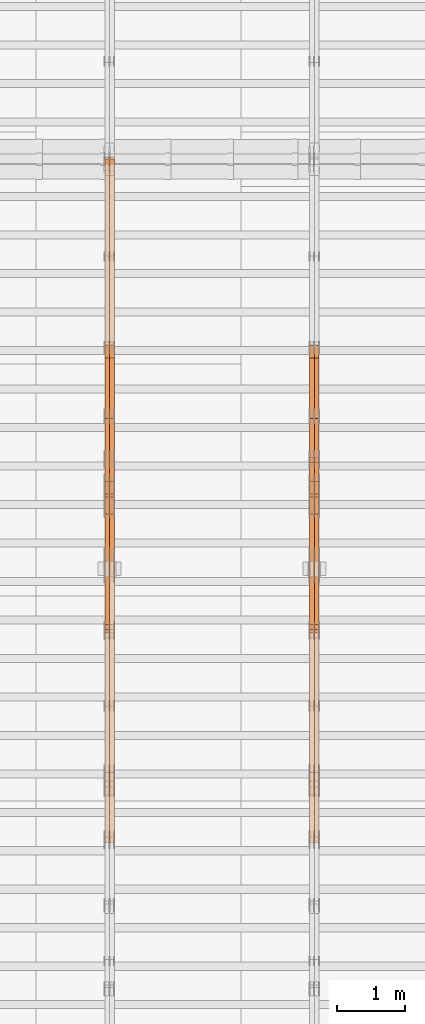
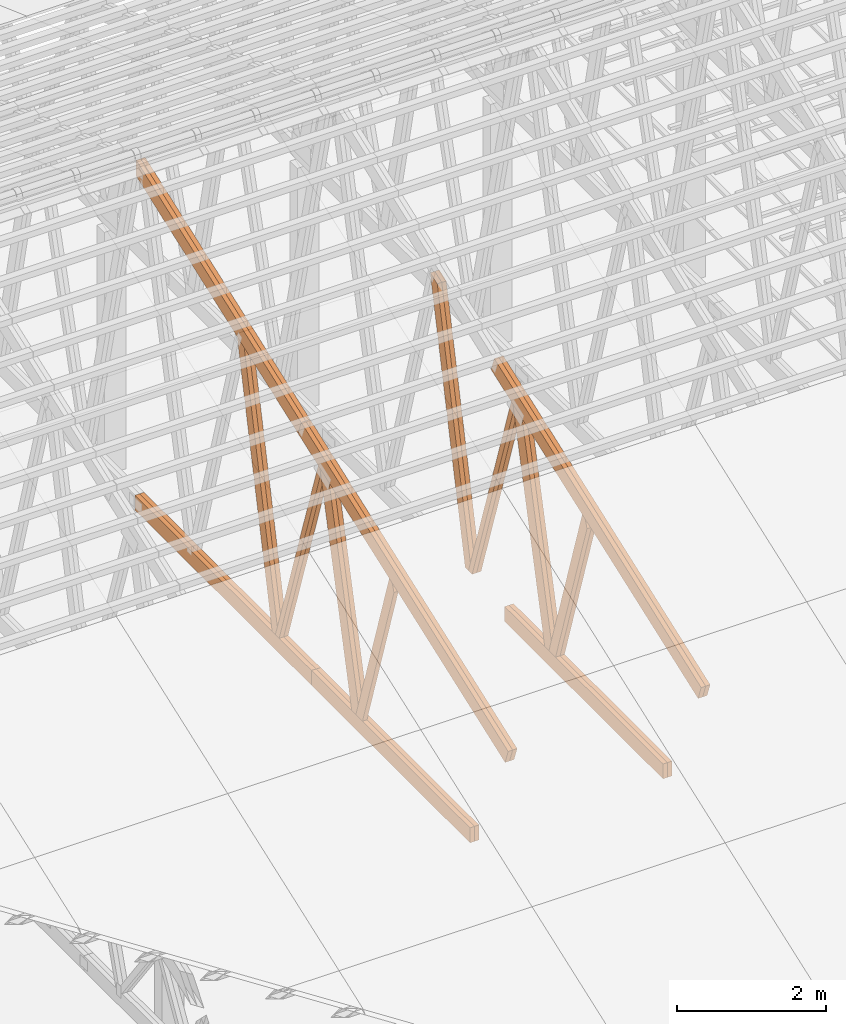
# One storey, part 49 of 189: 27 proxies.
"""IFC2X3 building model written with IfcOpenShell, lengths in millimetres."""

from ifc_helpers import new_model, entity, si_unit, converted_unit, derived_unit, direction, frame, origin, origin_2d_with_axis, place, context, subcontext, project, spatial, polyline, rectangle, outline, extrude, source, transform, mapped, material, type_object, type_shapes, element, save


model = new_model("IFC2X3")

# Units and contexts
model_context = context("Model", 3, precision=0.01, world=origin(), true_north=direction((6.12303176911189e-17, 1.0)))
body_context = subcontext(model_context, "Body", "Model", "MODEL_VIEW")
ifc_project = project(units=[si_unit("LENGTHUNIT", "METRE", prefix="MILLI"), si_unit("AREAUNIT", "SQUARE_METRE"), si_unit("VOLUMEUNIT", "CUBIC_METRE"), converted_unit("PLANEANGLEUNIT", "DEGREE", entity("IfcRatioMeasure", 0.0174532925199433), si_unit("PLANEANGLEUNIT", "RADIAN"), dimensions=[0, 0, 0, 0, 0, 0, 0]), si_unit("MASSUNIT", "GRAM", prefix="KILO"), derived_unit("MASSDENSITYUNIT", [(si_unit("MASSUNIT", "GRAM", prefix="KILO"), 1), (si_unit("LENGTHUNIT", "METRE"), -3)]), si_unit("TIMEUNIT", "SECOND"), si_unit("FREQUENCYUNIT", "HERTZ"), si_unit("THERMODYNAMICTEMPERATUREUNIT", "DEGREE_CELSIUS"), derived_unit("THERMALTRANSMITTANCEUNIT", [(si_unit("MASSUNIT", "GRAM", prefix="KILO"), 1), (si_unit("THERMODYNAMICTEMPERATUREUNIT", "KELVIN"), -1), (si_unit("TIMEUNIT", "SECOND"), -3)]), derived_unit("VOLUMETRICFLOWRATEUNIT", [(si_unit("LENGTHUNIT", "METRE"), 3), (si_unit("TIMEUNIT", "SECOND"), -1)]), si_unit("ELECTRICCURRENTUNIT", "AMPERE"), si_unit("ELECTRICVOLTAGEUNIT", "VOLT"), si_unit("POWERUNIT", "WATT"), si_unit("FORCEUNIT", "NEWTON"), si_unit("ILLUMINANCEUNIT", "LUX"), si_unit("LUMINOUSFLUXUNIT", "LUMEN"), si_unit("LUMINOUSINTENSITYUNIT", "CANDELA"), derived_unit("USERDEFINED", [(si_unit("MASSUNIT", "GRAM", prefix="KILO"), -1), (si_unit("LENGTHUNIT", "METRE"), -2), (si_unit("TIMEUNIT", "SECOND"), 3), (si_unit("LUMINOUSFLUXUNIT", "LUMEN"), 1)]), derived_unit("LINEARVELOCITYUNIT", [(si_unit("LENGTHUNIT", "METRE"), 1), (si_unit("TIMEUNIT", "SECOND"), -1)]), si_unit("PRESSUREUNIT", "PASCAL"), derived_unit("USERDEFINED", [(si_unit("LENGTHUNIT", "METRE"), -2), (si_unit("MASSUNIT", "GRAM", prefix="KILO"), 1), (si_unit("TIMEUNIT", "SECOND"), -2)])], contexts=[model_context])

# Site, building, storey
site_placement = place(None, origin())
site = spatial("IfcSite", under=ifc_project, at=site_placement, CompositionType="ELEMENT")
building_placement = place(site_placement, origin())
building = spatial("IfcBuilding", under=site, at=building_placement, CompositionType="ELEMENT")
storey_placement = place(building_placement, origin())
storey = spatial("IfcBuildingStorey", under=building, at=storey_placement, Name="Default", CompositionType="ELEMENT", Elevation=0.0)

# Proxies
ifc_material_1 = material(Name="IfcSurfaceStyle #194426")
building_element_proxy_type_1 = type_object("IfcBuildingElementProxyType", Name="T1-W3 194424", PredefinedType="NOTDEFINED", material=ifc_material_1)
shared_shape_1 = source(origin(), body_context, "Body", "SweptSolid", [
    extrude(outline(polyline([(-2625.55080717397, -84.9998286237256), (1749.48871563991, -84.9998286237256), (1768.20584427244, 0.000602085469291858), (1625.445846867, 85.0000405971208), (-2517.58959960538, 84.9990145648612), (-2625.55080717397, -84.9998286237256)])), frame((1768.20584427244, 85.0000405971208, 0.0), z_axis=(0.0, 0.0, 1.0), x_axis=(-1.0, 0.0, 0.0)), (0.0, 0.0, 1.0), 69.9999999999997),
])
type_shapes(building_element_proxy_type_1, [shared_shape_1])
proxy_1_placement = place(building_placement, frame((36300.0, 10918.6728403286, 263.278932236374), z_axis=(-1.0, 0.0, 0.0), x_axis=(0.0, 0.215047682154604, 0.976603550269982)))
element("IfcBuildingElementProxy", 1, at=proxy_1_placement, inside=storey, type_object=building_element_proxy_type_1, material=ifc_material_1, Name="T1-W3", context=body_context, shape_type="MappedRepresentation", body=[
    mapped(shared_shape_1, transform((0.0, 0.0, 0.0), scale=1.0)),
])
ifc_material_2 = material(Name="IfcSurfaceStyle #194360")
building_element_proxy_type_2 = type_object("IfcBuildingElementProxyType", Name="T1-W3 194358", PredefinedType="NOTDEFINED", material=ifc_material_2)
shared_shape_2 = source(origin(), body_context, "Body", "SweptSolid", [
    extrude(outline(polyline([(-2625.55080717397, -84.9998286237256), (1749.48871563991, -84.9998286237256), (1768.20584427244, 0.000602085469291858), (1625.445846867, 85.0000405971208), (-2517.58959960538, 84.9990145648612), (-2625.55080717397, -84.9998286237256)])), frame((1768.20584427244, 85.0000405971208, 0.0), z_axis=(0.0, 0.0, 1.0), x_axis=(-1.0, 0.0, 0.0)), (0.0, 0.0, 1.0), 69.9999999999997),
])
type_shapes(building_element_proxy_type_2, [shared_shape_2])
proxy_2_placement = place(building_placement, frame((36230.0, 10918.6728403286, 263.278932236374), z_axis=(-1.0, 0.0, 0.0), x_axis=(0.0, 0.215047682154604, 0.976603550269982)))
element("IfcBuildingElementProxy", 2, at=proxy_2_placement, inside=storey, type_object=building_element_proxy_type_2, material=ifc_material_2, Name="T1-W3", context=body_context, shape_type="MappedRepresentation", body=[
    mapped(shared_shape_2, transform((0.0, 0.0, 0.0), scale=1.0)),
])
ifc_material_3 = material(Name="IfcSurfaceStyle #194162")
building_element_proxy_type_3 = type_object("IfcBuildingElementProxyType", Name="T1-W7 194160", PredefinedType="NOTDEFINED", material=ifc_material_3)
shared_shape_3 = source(origin(), body_context, "Body", "SweptSolid", [
    extrude(outline(polyline([(-2158.15323194511, -47.5001976605119), (1398.58481981178, -47.5001976605119), (1473.93376219819, -0.000131511554346808), (1475.30069254941, 47.5002634162891), (-2189.66604261427, 47.5002634162891), (-2158.15323194511, -47.5001976605119)])), frame((1475.30069254941, 47.5002634162891, 0.0), z_axis=(0.0, 0.0, 1.0), x_axis=(-1.0, 0.0, 0.0)), (0.0, 0.0, 1.0), 69.9999999999998),
])
type_shapes(building_element_proxy_type_3, [shared_shape_3])
proxy_3_placement = place(building_placement, frame((36300.0, 9847.787109375, 3723.57788085937), z_axis=(-1.0, 0.0, 0.0), x_axis=(0.0, 0.314845237923105, -0.949143021971475)))
element("IfcBuildingElementProxy", 3, at=proxy_3_placement, inside=storey, type_object=building_element_proxy_type_3, material=ifc_material_3, Name="T1-W7", context=body_context, shape_type="MappedRepresentation", body=[
    mapped(shared_shape_3, transform((0.0, 0.0, 0.0), scale=1.0)),
])
ifc_material_4 = material(Name="IfcSurfaceStyle #194096")
building_element_proxy_type_4 = type_object("IfcBuildingElementProxyType", Name="T1-W7 194094", PredefinedType="NOTDEFINED", material=ifc_material_4)
shared_shape_4 = source(origin(), body_context, "Body", "SweptSolid", [
    extrude(outline(polyline([(-2158.15323194511, -47.5001976605119), (1398.58481981178, -47.5001976605119), (1473.93376219819, -0.000131511554346808), (1475.30069254941, 47.5002634162891), (-2189.66604261427, 47.5002634162891), (-2158.15323194511, -47.5001976605119)])), frame((1475.30069254941, 47.5002634162891, 0.0), z_axis=(0.0, 0.0, 1.0), x_axis=(-1.0, 0.0, 0.0)), (0.0, 0.0, 1.0), 69.9999999999998),
])
type_shapes(building_element_proxy_type_4, [shared_shape_4])
proxy_4_placement = place(building_placement, frame((36230.0, 9847.787109375, 3723.57788085937), z_axis=(-1.0, 0.0, 0.0), x_axis=(0.0, 0.314845237923105, -0.949143021971475)))
element("IfcBuildingElementProxy", 4, at=proxy_4_placement, inside=storey, type_object=building_element_proxy_type_4, material=ifc_material_4, Name="T1-W7", context=body_context, shape_type="MappedRepresentation", body=[
    mapped(shared_shape_4, transform((0.0, 0.0, 0.0), scale=1.0)),
])
ifc_material_5 = material(Name="IfcSurfaceStyle #193898")
building_element_proxy_type_5 = type_object("IfcBuildingElementProxyType", Name="T1-W1 193896", PredefinedType="NOTDEFINED", material=ifc_material_5)
shared_shape_5 = source(origin(), body_context, "Body", "SweptSolid", [
    extrude(outline(polyline([(-2144.69382208629, -109.99948311278), (1421.70798092021, -109.99948311278), (1448.88116133745, -0.000392715405943322), (1271.09900468242, 109.999679470483), (-1996.99432485378, 109.999679470483), (-2144.69382208629, -109.99948311278)])), frame((1448.88130194731, 110.000176487146, 0.0), z_axis=(0.0, 0.0, 1.0), x_axis=(-1.0, 0.0, 0.0)), (0.0, 0.0, 1.0), 69.9999999999998),
])
type_shapes(building_element_proxy_type_5, [shared_shape_5])
proxy_5_placement = place(building_placement, frame((36300.0, 8727.74270166583, 271.380182391418), z_axis=(-1.0, 0.0, 0.0), x_axis=(0.0, 0.239819839925978, 0.970817410421691)))
element("IfcBuildingElementProxy", 5, at=proxy_5_placement, inside=storey, type_object=building_element_proxy_type_5, material=ifc_material_5, Name="T1-W1", context=body_context, shape_type="MappedRepresentation", body=[
    mapped(shared_shape_5, transform((0.0, 0.0, 0.0), scale=1.0)),
])
ifc_material_6 = material(Name="IfcSurfaceStyle #193832")
building_element_proxy_type_6 = type_object("IfcBuildingElementProxyType", Name="T1-W1 193830", PredefinedType="NOTDEFINED", material=ifc_material_6)
shared_shape_6 = source(origin(), body_context, "Body", "SweptSolid", [
    extrude(outline(polyline([(-2144.69382208629, -109.99948311278), (1421.70798092021, -109.99948311278), (1448.88116133745, -0.000392715405943322), (1271.09900468242, 109.999679470483), (-1996.99432485378, 109.999679470483), (-2144.69382208629, -109.99948311278)])), frame((1448.88130194731, 110.000176487146, 0.0), z_axis=(0.0, 0.0, 1.0), x_axis=(-1.0, 0.0, 0.0)), (0.0, 0.0, 1.0), 69.9999999999998),
])
type_shapes(building_element_proxy_type_6, [shared_shape_6])
proxy_6_placement = place(building_placement, frame((36230.0, 8727.74270166583, 271.380182391418), z_axis=(-1.0, 0.0, 0.0), x_axis=(0.0, 0.239819839925978, 0.970817410421691)))
element("IfcBuildingElementProxy", 6, at=proxy_6_placement, inside=storey, type_object=building_element_proxy_type_6, material=ifc_material_6, Name="T1-W1", context=body_context, shape_type="MappedRepresentation", body=[
    mapped(shared_shape_6, transform((0.0, 0.0, 0.0), scale=1.0)),
])
ifc_material_7 = material(Name="IfcSurfaceStyle #193634")
building_element_proxy_type_7 = type_object("IfcBuildingElementProxyType", Name="T1-W4 193632", PredefinedType="NOTDEFINED", material=ifc_material_7)
shared_shape_7 = source(origin(), body_context, "Body", "SweptSolid", [
    extrude(outline(polyline([(-1688.09292256655, -85.0003489723785), (1071.44998120742, -85.0003489723785), (1178.19407811536, -0.00016040063201781), (1181.35435681367, 85.0004291726946), (-1742.9054935699, 85.0004291726946), (-1688.09292256655, -85.0003489723785)])), frame((1181.35446122976, 85.0007670757732, 0.0), z_axis=(0.0, 0.0, 1.0), x_axis=(-1.0, 0.0, 0.0)), (0.0, 0.0, 1.0), 69.9999999999998),
])
type_shapes(building_element_proxy_type_7, [shared_shape_7])
proxy_7_placement = place(building_placement, frame((36300.0, 7937.17021143291, 3028.170124945), z_axis=(-1.0, 0.0, 0.0), x_axis=(0.0, 0.306868406216492, -0.951751953644514)))
element("IfcBuildingElementProxy", 7, at=proxy_7_placement, inside=storey, type_object=building_element_proxy_type_7, material=ifc_material_7, Name="T1-W4", context=body_context, shape_type="MappedRepresentation", body=[
    mapped(shared_shape_7, transform((0.0, 0.0, 0.0), scale=1.0)),
])
ifc_material_8 = material(Name="IfcSurfaceStyle #193568")
building_element_proxy_type_8 = type_object("IfcBuildingElementProxyType", Name="T1-W4 193566", PredefinedType="NOTDEFINED", material=ifc_material_8)
shared_shape_8 = source(origin(), body_context, "Body", "SweptSolid", [
    extrude(outline(polyline([(-1688.09292256655, -85.0003489723785), (1071.44998120742, -85.0003489723785), (1178.19407811536, -0.00016040063201781), (1181.35435681367, 85.0004291726946), (-1742.9054935699, 85.0004291726946), (-1688.09292256655, -85.0003489723785)])), frame((1181.35446122976, 85.0007670757732, 0.0), z_axis=(0.0, 0.0, 1.0), x_axis=(-1.0, 0.0, 0.0)), (0.0, 0.0, 1.0), 69.9999999999998),
])
type_shapes(building_element_proxy_type_8, [shared_shape_8])
proxy_8_placement = place(building_placement, frame((36230.0, 7937.17021143291, 3028.170124945), z_axis=(-1.0, 0.0, 0.0), x_axis=(0.0, 0.306868406216492, -0.951751953644514)))
element("IfcBuildingElementProxy", 8, at=proxy_8_placement, inside=storey, type_object=building_element_proxy_type_8, material=ifc_material_8, Name="T1-W4", context=body_context, shape_type="MappedRepresentation", body=[
    mapped(shared_shape_8, transform((0.0, 0.0, 0.0), scale=1.0)),
])
ifc_material_9 = material(Name="IfcSurfaceStyle #190556")
building_element_proxy_type_9 = type_object("IfcBuildingElementProxyType", Name="T1-B6 190554", PredefinedType="NOTDEFINED", material=ifc_material_9)
shared_shape_9 = source(origin(), body_context, "Body", "SweptSolid", [
    extrude(rectangle(XDim=4266.763671875, YDim=245.000000000001, at=origin_2d_with_axis()), frame((2133.3818359375, 122.500000000001, 0.0), z_axis=(0.0, 0.0, 1.0), x_axis=(-1.0, 0.0, 0.0)), (0.0, 0.0, 1.0), 69.9999999999997),
])
type_shapes(building_element_proxy_type_9, [shared_shape_9])
proxy_9_placement = place(building_placement, frame((36300.0, 5762.466796875, 245.0), z_axis=(-1.0, 0.0, 0.0), x_axis=(0.0, 1.0, 0.0)))
element("IfcBuildingElementProxy", 9, at=proxy_9_placement, inside=storey, type_object=building_element_proxy_type_9, material=ifc_material_9, Name="T1-B6", context=body_context, shape_type="MappedRepresentation", body=[
    mapped(shared_shape_9, transform((0.0, 0.0, 0.0), scale=1.0)),
])
ifc_material_10 = material(Name="IfcSurfaceStyle #190499")
building_element_proxy_type_10 = type_object("IfcBuildingElementProxyType", Name="T1-B6 190497", PredefinedType="NOTDEFINED", material=ifc_material_10)
shared_shape_10 = source(origin(), body_context, "Body", "SweptSolid", [
    extrude(rectangle(XDim=4266.763671875, YDim=245.000000000001, at=origin_2d_with_axis()), frame((2133.3818359375, 122.500000000001, 0.0), z_axis=(0.0, 0.0, 1.0), x_axis=(-1.0, 0.0, 0.0)), (0.0, 0.0, 1.0), 69.9999999999997),
])
type_shapes(building_element_proxy_type_10, [shared_shape_10])
proxy_10_placement = place(building_placement, frame((36230.0, 5762.466796875, 245.0), z_axis=(-1.0, 0.0, 0.0), x_axis=(0.0, 1.0, 0.0)))
element("IfcBuildingElementProxy", 10, at=proxy_10_placement, inside=storey, type_object=building_element_proxy_type_10, material=ifc_material_10, Name="T1-B6", context=body_context, shape_type="MappedRepresentation", body=[
    mapped(shared_shape_10, transform((0.0, 0.0, 0.0), scale=1.0)),
])
ifc_material_11 = material(Name="IfcSurfaceStyle #190196")
building_element_proxy_type_11 = type_object("IfcBuildingElementProxyType", Name="T1-T1 190194", PredefinedType="NOTDEFINED", material=ifc_material_11)
shared_shape_11 = source(origin(), body_context, "Body", "SweptSolid", [
    extrude(outline(polyline([(-2964.99981923522, -122.500027388895), (2964.99982426074, -122.500027388895), (2964.99984011048, 122.500027388895), (-2964.99984513599, 122.500027388895), (-2964.99981923522, -122.500027388895)])), frame((2965.00021857317, 122.500056320695, 0.0), z_axis=(0.0, 0.0, 1.0), x_axis=(-1.0, 0.0, 0.0)), (0.0, 0.0, 1.0), 69.9999999999996),
])
type_shapes(building_element_proxy_type_11, [shared_shape_11])
proxy_11_placement = place(building_placement, frame((36300.0, 10391.0374749089, 3921.30478975487), z_axis=(-1.0, 0.0, 0.0), x_axis=(0.0, -0.939692620785908, -0.342020143325669)))
element("IfcBuildingElementProxy", 11, at=proxy_11_placement, inside=storey, type_object=building_element_proxy_type_11, material=ifc_material_11, Name="T1-T1", context=body_context, shape_type="MappedRepresentation", body=[
    mapped(shared_shape_11, transform((0.0, 0.0, 0.0), scale=1.0)),
])
ifc_material_12 = material(Name="IfcSurfaceStyle #190139")
building_element_proxy_type_12 = type_object("IfcBuildingElementProxyType", Name="T1-T1 190137", PredefinedType="NOTDEFINED", material=ifc_material_12)
shared_shape_12 = source(origin(), body_context, "Body", "SweptSolid", [
    extrude(outline(polyline([(-2964.99981923522, -122.500027388895), (2964.99982426074, -122.500027388895), (2964.99984011048, 122.500027388895), (-2964.99984513599, 122.500027388895), (-2964.99981923522, -122.500027388895)])), frame((2965.00021857317, 122.500056320695, 0.0), z_axis=(0.0, 0.0, 1.0), x_axis=(-1.0, 0.0, 0.0)), (0.0, 0.0, 1.0), 69.9999999999996),
])
type_shapes(building_element_proxy_type_12, [shared_shape_12])
proxy_12_placement = place(building_placement, frame((36230.0, 10391.0374749089, 3921.30478975487), z_axis=(-1.0, 0.0, 0.0), x_axis=(0.0, -0.939692620785908, -0.342020143325669)))
element("IfcBuildingElementProxy", 12, at=proxy_12_placement, inside=storey, type_object=building_element_proxy_type_12, material=ifc_material_12, Name="T1-T1", context=body_context, shape_type="MappedRepresentation", body=[
    mapped(shared_shape_12, transform((0.0, 0.0, 0.0), scale=1.0)),
])
ifc_material_13 = material(Name="IfcSurfaceStyle #178636")
building_element_proxy_type_13 = type_object("IfcBuildingElementProxyType", Name="T1-W3 178634", PredefinedType="NOTDEFINED", material=ifc_material_13)
shared_shape_13 = source(origin(), body_context, "Body", "SweptSolid", [
    extrude(outline(polyline([(-2625.55080717397, -84.9998286237256), (1749.48871563991, -84.9998286237256), (1768.20584427244, 0.000602085469291858), (1625.445846867, 85.0000405971208), (-2517.58959960538, 84.9990145648612), (-2625.55080717397, -84.9998286237256)])), frame((1768.20584427244, 85.0000405971208, 0.0), z_axis=(0.0, 0.0, 1.0), x_axis=(-1.0, 0.0, 0.0)), (0.0, 0.0, 1.0), 69.9999999999997),
])
type_shapes(building_element_proxy_type_13, [shared_shape_13])
proxy_13_placement = place(building_placement, frame((33300.0, 10918.6728403286, 263.278932236374), z_axis=(-1.0, 0.0, 0.0), x_axis=(0.0, 0.215047682154604, 0.976603550269982)))
element("IfcBuildingElementProxy", 13, at=proxy_13_placement, inside=storey, type_object=building_element_proxy_type_13, material=ifc_material_13, Name="T1-W3", context=body_context, shape_type="MappedRepresentation", body=[
    mapped(shared_shape_13, transform((0.0, 0.0, 0.0), scale=1.0)),
])
ifc_material_14 = material(Name="IfcSurfaceStyle #178570")
building_element_proxy_type_14 = type_object("IfcBuildingElementProxyType", Name="T1-W3 178568", PredefinedType="NOTDEFINED", material=ifc_material_14)
shared_shape_14 = source(origin(), body_context, "Body", "SweptSolid", [
    extrude(outline(polyline([(-2625.55080717397, -84.9998286237256), (1749.48871563991, -84.9998286237256), (1768.20584427244, 0.000602085469291858), (1625.445846867, 85.0000405971208), (-2517.58959960538, 84.9990145648612), (-2625.55080717397, -84.9998286237256)])), frame((1768.20584427244, 85.0000405971208, 0.0), z_axis=(0.0, 0.0, 1.0), x_axis=(-1.0, 0.0, 0.0)), (0.0, 0.0, 1.0), 69.9999999999997),
])
type_shapes(building_element_proxy_type_14, [shared_shape_14])
proxy_14_placement = place(building_placement, frame((33230.0, 10918.6728403286, 263.278932236374), z_axis=(-1.0, 0.0, 0.0), x_axis=(0.0, 0.215047682154604, 0.976603550269982)))
element("IfcBuildingElementProxy", 14, at=proxy_14_placement, inside=storey, type_object=building_element_proxy_type_14, material=ifc_material_14, Name="T1-W3", context=body_context, shape_type="MappedRepresentation", body=[
    mapped(shared_shape_14, transform((0.0, 0.0, 0.0), scale=1.0)),
])
ifc_material_15 = material(Name="IfcSurfaceStyle #178372")
building_element_proxy_type_15 = type_object("IfcBuildingElementProxyType", Name="T1-W7 178370", PredefinedType="NOTDEFINED", material=ifc_material_15)
shared_shape_15 = source(origin(), body_context, "Body", "SweptSolid", [
    extrude(outline(polyline([(-2158.15323194511, -47.5001976605119), (1398.58481981178, -47.5001976605119), (1473.93376219819, -0.000131511554346808), (1475.30069254941, 47.5002634162891), (-2189.66604261427, 47.5002634162891), (-2158.15323194511, -47.5001976605119)])), frame((1475.30069254941, 47.5002634162891, 0.0), z_axis=(0.0, 0.0, 1.0), x_axis=(-1.0, 0.0, 0.0)), (0.0, 0.0, 1.0), 69.9999999999998),
])
type_shapes(building_element_proxy_type_15, [shared_shape_15])
proxy_15_placement = place(building_placement, frame((33300.0, 9847.787109375, 3723.57788085937), z_axis=(-1.0, 0.0, 0.0), x_axis=(0.0, 0.314845237923105, -0.949143021971475)))
element("IfcBuildingElementProxy", 15, at=proxy_15_placement, inside=storey, type_object=building_element_proxy_type_15, material=ifc_material_15, Name="T1-W7", context=body_context, shape_type="MappedRepresentation", body=[
    mapped(shared_shape_15, transform((0.0, 0.0, 0.0), scale=1.0)),
])
ifc_material_16 = material(Name="IfcSurfaceStyle #178306")
building_element_proxy_type_16 = type_object("IfcBuildingElementProxyType", Name="T1-W7 178304", PredefinedType="NOTDEFINED", material=ifc_material_16)
shared_shape_16 = source(origin(), body_context, "Body", "SweptSolid", [
    extrude(outline(polyline([(-2158.15323194511, -47.5001976605119), (1398.58481981178, -47.5001976605119), (1473.93376219819, -0.000131511554346808), (1475.30069254941, 47.5002634162891), (-2189.66604261427, 47.5002634162891), (-2158.15323194511, -47.5001976605119)])), frame((1475.30069254941, 47.5002634162891, 0.0), z_axis=(0.0, 0.0, 1.0), x_axis=(-1.0, 0.0, 0.0)), (0.0, 0.0, 1.0), 69.9999999999998),
])
type_shapes(building_element_proxy_type_16, [shared_shape_16])
proxy_16_placement = place(building_placement, frame((33230.0, 9847.787109375, 3723.57788085937), z_axis=(-1.0, 0.0, 0.0), x_axis=(0.0, 0.314845237923105, -0.949143021971475)))
element("IfcBuildingElementProxy", 16, at=proxy_16_placement, inside=storey, type_object=building_element_proxy_type_16, material=ifc_material_16, Name="T1-W7", context=body_context, shape_type="MappedRepresentation", body=[
    mapped(shared_shape_16, transform((0.0, 0.0, 0.0), scale=1.0)),
])
ifc_material_17 = material(Name="IfcSurfaceStyle #178108")
building_element_proxy_type_17 = type_object("IfcBuildingElementProxyType", Name="T1-W1 178106", PredefinedType="NOTDEFINED", material=ifc_material_17)
shared_shape_17 = source(origin(), body_context, "Body", "SweptSolid", [
    extrude(outline(polyline([(-2144.69382208629, -109.99948311278), (1421.70798092021, -109.99948311278), (1448.88116133745, -0.000392715405943322), (1271.09900468242, 109.999679470483), (-1996.99432485378, 109.999679470483), (-2144.69382208629, -109.99948311278)])), frame((1448.88130194731, 110.000176487146, 0.0), z_axis=(0.0, 0.0, 1.0), x_axis=(-1.0, 0.0, 0.0)), (0.0, 0.0, 1.0), 69.9999999999998),
])
type_shapes(building_element_proxy_type_17, [shared_shape_17])
proxy_17_placement = place(building_placement, frame((33300.0, 8727.74270166583, 271.380182391418), z_axis=(-1.0, 0.0, 0.0), x_axis=(0.0, 0.239819839925978, 0.970817410421691)))
element("IfcBuildingElementProxy", 17, at=proxy_17_placement, inside=storey, type_object=building_element_proxy_type_17, material=ifc_material_17, Name="T1-W1", context=body_context, shape_type="MappedRepresentation", body=[
    mapped(shared_shape_17, transform((0.0, 0.0, 0.0), scale=1.0)),
])
ifc_material_18 = material(Name="IfcSurfaceStyle #178042")
building_element_proxy_type_18 = type_object("IfcBuildingElementProxyType", Name="T1-W1 178040", PredefinedType="NOTDEFINED", material=ifc_material_18)
shared_shape_18 = source(origin(), body_context, "Body", "SweptSolid", [
    extrude(outline(polyline([(-2144.69382208629, -109.99948311278), (1421.70798092021, -109.99948311278), (1448.88116133745, -0.000392715405943322), (1271.09900468242, 109.999679470483), (-1996.99432485378, 109.999679470483), (-2144.69382208629, -109.99948311278)])), frame((1448.88130194731, 110.000176487146, 0.0), z_axis=(0.0, 0.0, 1.0), x_axis=(-1.0, 0.0, 0.0)), (0.0, 0.0, 1.0), 69.9999999999998),
])
type_shapes(building_element_proxy_type_18, [shared_shape_18])
proxy_18_placement = place(building_placement, frame((33230.0, 8727.74270166583, 271.380182391418), z_axis=(-1.0, 0.0, 0.0), x_axis=(0.0, 0.239819839925978, 0.970817410421691)))
element("IfcBuildingElementProxy", 18, at=proxy_18_placement, inside=storey, type_object=building_element_proxy_type_18, material=ifc_material_18, Name="T1-W1", context=body_context, shape_type="MappedRepresentation", body=[
    mapped(shared_shape_18, transform((0.0, 0.0, 0.0), scale=1.0)),
])
ifc_material_19 = material(Name="IfcSurfaceStyle #177778")
building_element_proxy_type_19 = type_object("IfcBuildingElementProxyType", Name="T1-W4 177776", PredefinedType="NOTDEFINED", material=ifc_material_19)
shared_shape_19 = source(origin(), body_context, "Body", "SweptSolid", [
    extrude(outline(polyline([(-1688.09292256655, -85.0003489723785), (1071.44998120742, -85.0003489723785), (1178.19407811536, -0.00016040063201781), (1181.35435681367, 85.0004291726946), (-1742.9054935699, 85.0004291726946), (-1688.09292256655, -85.0003489723785)])), frame((1181.35446122976, 85.0007670757732, 0.0), z_axis=(0.0, 0.0, 1.0), x_axis=(-1.0, 0.0, 0.0)), (0.0, 0.0, 1.0), 69.9999999999998),
])
type_shapes(building_element_proxy_type_19, [shared_shape_19])
proxy_19_placement = place(building_placement, frame((33230.0, 7937.17021143291, 3028.170124945), z_axis=(-1.0, 0.0, 0.0), x_axis=(0.0, 0.306868406216492, -0.951751953644514)))
element("IfcBuildingElementProxy", 19, at=proxy_19_placement, inside=storey, type_object=building_element_proxy_type_19, material=ifc_material_19, Name="T1-W4", context=body_context, shape_type="MappedRepresentation", body=[
    mapped(shared_shape_19, transform((0.0, 0.0, 0.0), scale=1.0)),
])
ifc_material_20 = material(Name="IfcSurfaceStyle #174880")
building_element_proxy_type_20 = type_object("IfcBuildingElementProxyType", Name="T1-B3 174878", PredefinedType="NOTDEFINED", material=ifc_material_20)
shared_shape_20 = source(origin(), body_context, "Body", "SweptSolid", [
    extrude(rectangle(XDim=4751.0283203125, YDim=245.000000000001, at=origin_2d_with_axis()), frame((2375.51416015625, 122.5, 0.0), z_axis=(0.0, 0.0, 1.0), x_axis=(-1.0, 0.0, 0.0)), (0.0, 0.0, 1.0), 69.9999999999997),
])
type_shapes(building_element_proxy_type_20, [shared_shape_20])
proxy_20_placement = place(building_placement, frame((33300.0, 10029.23046875, 245.0), z_axis=(-1.0, 0.0, 0.0), x_axis=(0.0, 1.0, 0.0)))
element("IfcBuildingElementProxy", 20, at=proxy_20_placement, inside=storey, type_object=building_element_proxy_type_20, material=ifc_material_20, Name="T1-B3", context=body_context, shape_type="MappedRepresentation", body=[
    mapped(shared_shape_20, transform((0.0, 0.0, 0.0), scale=1.0)),
])
ifc_material_21 = material(Name="IfcSurfaceStyle #174823")
building_element_proxy_type_21 = type_object("IfcBuildingElementProxyType", Name="T1-B3 174821", PredefinedType="NOTDEFINED", material=ifc_material_21)
shared_shape_21 = source(origin(), body_context, "Body", "SweptSolid", [
    extrude(rectangle(XDim=4751.0283203125, YDim=245.000000000001, at=origin_2d_with_axis()), frame((2375.51416015625, 122.5, 0.0), z_axis=(0.0, 0.0, 1.0), x_axis=(-1.0, 0.0, 0.0)), (0.0, 0.0, 1.0), 69.9999999999997),
])
type_shapes(building_element_proxy_type_21, [shared_shape_21])
proxy_21_placement = place(building_placement, frame((33230.0, 10029.23046875, 245.0), z_axis=(-1.0, 0.0, 0.0), x_axis=(0.0, 1.0, 0.0)))
element("IfcBuildingElementProxy", 21, at=proxy_21_placement, inside=storey, type_object=building_element_proxy_type_21, material=ifc_material_21, Name="T1-B3", context=body_context, shape_type="MappedRepresentation", body=[
    mapped(shared_shape_21, transform((0.0, 0.0, 0.0), scale=1.0)),
])
ifc_material_22 = material(Name="IfcSurfaceStyle #174766")
building_element_proxy_type_22 = type_object("IfcBuildingElementProxyType", Name="T1-B6 174764", PredefinedType="NOTDEFINED", material=ifc_material_22)
shared_shape_22 = source(origin(), body_context, "Body", "SweptSolid", [
    extrude(rectangle(XDim=4266.763671875, YDim=245.000000000001, at=origin_2d_with_axis()), frame((2133.3818359375, 122.500000000001, 0.0), z_axis=(0.0, 0.0, 1.0), x_axis=(-1.0, 0.0, 0.0)), (0.0, 0.0, 1.0), 69.9999999999997),
])
type_shapes(building_element_proxy_type_22, [shared_shape_22])
proxy_22_placement = place(building_placement, frame((33300.0, 5762.466796875, 245.0), z_axis=(-1.0, 0.0, 0.0), x_axis=(0.0, 1.0, 0.0)))
element("IfcBuildingElementProxy", 22, at=proxy_22_placement, inside=storey, type_object=building_element_proxy_type_22, material=ifc_material_22, Name="T1-B6", context=body_context, shape_type="MappedRepresentation", body=[
    mapped(shared_shape_22, transform((0.0, 0.0, 0.0), scale=1.0)),
])
ifc_material_23 = material(Name="IfcSurfaceStyle #174709")
building_element_proxy_type_23 = type_object("IfcBuildingElementProxyType", Name="T1-B6 174707", PredefinedType="NOTDEFINED", material=ifc_material_23)
shared_shape_23 = source(origin(), body_context, "Body", "SweptSolid", [
    extrude(rectangle(XDim=4266.763671875, YDim=245.000000000001, at=origin_2d_with_axis()), frame((2133.3818359375, 122.500000000001, 0.0), z_axis=(0.0, 0.0, 1.0), x_axis=(-1.0, 0.0, 0.0)), (0.0, 0.0, 1.0), 69.9999999999997),
])
type_shapes(building_element_proxy_type_23, [shared_shape_23])
proxy_23_placement = place(building_placement, frame((33230.0, 5762.466796875, 245.0), z_axis=(-1.0, 0.0, 0.0), x_axis=(0.0, 1.0, 0.0)))
element("IfcBuildingElementProxy", 23, at=proxy_23_placement, inside=storey, type_object=building_element_proxy_type_23, material=ifc_material_23, Name="T1-B6", context=body_context, shape_type="MappedRepresentation", body=[
    mapped(shared_shape_23, transform((0.0, 0.0, 0.0), scale=1.0)),
])
ifc_material_24 = material(Name="IfcSurfaceStyle #174406")
building_element_proxy_type_24 = type_object("IfcBuildingElementProxyType", Name="T1-T1 174404", PredefinedType="NOTDEFINED", material=ifc_material_24)
shared_shape_24 = source(origin(), body_context, "Body", "SweptSolid", [
    extrude(outline(polyline([(-2964.99981923522, -122.500027388895), (2964.99982426074, -122.500027388895), (2964.99984011048, 122.500027388895), (-2964.99984513599, 122.500027388895), (-2964.99981923522, -122.500027388895)])), frame((2965.00021857317, 122.500056320695, 0.0), z_axis=(0.0, 0.0, 1.0), x_axis=(-1.0, 0.0, 0.0)), (0.0, 0.0, 1.0), 69.9999999999996),
])
type_shapes(building_element_proxy_type_24, [shared_shape_24])
proxy_24_placement = place(building_placement, frame((33300.0, 10391.0374749089, 3921.30478975487), z_axis=(-1.0, 0.0, 0.0), x_axis=(0.0, -0.939692620785908, -0.342020143325669)))
element("IfcBuildingElementProxy", 24, at=proxy_24_placement, inside=storey, type_object=building_element_proxy_type_24, material=ifc_material_24, Name="T1-T1", context=body_context, shape_type="MappedRepresentation", body=[
    mapped(shared_shape_24, transform((0.0, 0.0, 0.0), scale=1.0)),
])
ifc_material_25 = material(Name="IfcSurfaceStyle #174349")
building_element_proxy_type_25 = type_object("IfcBuildingElementProxyType", Name="T1-T1 174347", PredefinedType="NOTDEFINED", material=ifc_material_25)
shared_shape_25 = source(origin(), body_context, "Body", "SweptSolid", [
    extrude(outline(polyline([(-2964.99981923522, -122.500027388895), (2964.99982426074, -122.500027388895), (2964.99984011048, 122.500027388895), (-2964.99984513599, 122.500027388895), (-2964.99981923522, -122.500027388895)])), frame((2965.00021857317, 122.500056320695, 0.0), z_axis=(0.0, 0.0, 1.0), x_axis=(-1.0, 0.0, 0.0)), (0.0, 0.0, 1.0), 69.9999999999996),
])
type_shapes(building_element_proxy_type_25, [shared_shape_25])
proxy_25_placement = place(building_placement, frame((33230.0, 10391.0374749089, 3921.30478975487), z_axis=(-1.0, 0.0, 0.0), x_axis=(0.0, -0.939692620785908, -0.342020143325669)))
element("IfcBuildingElementProxy", 25, at=proxy_25_placement, inside=storey, type_object=building_element_proxy_type_25, material=ifc_material_25, Name="T1-T1", context=body_context, shape_type="MappedRepresentation", body=[
    mapped(shared_shape_25, transform((0.0, 0.0, 0.0), scale=1.0)),
])
ifc_material_26 = material(Name="IfcSurfaceStyle #174292")
building_element_proxy_type_26 = type_object("IfcBuildingElementProxyType", Name="T1-T3 174290", PredefinedType="NOTDEFINED", material=ifc_material_26)
shared_shape_26 = source(origin(), body_context, "Body", "SweptSolid", [
    extrude(outline(polyline([(-2341.64890001385, -122.499972785692), (2386.23525922045, -122.499972785692), (2297.06252495753, 122.499972785692), (-2341.64888416412, 122.499972785692), (-2341.64890001385, -122.499972785692)])), frame((2386.23525922045, 122.499973888764, 0.0), z_axis=(0.0, 0.0, 1.0), x_axis=(-1.0, 0.0, 0.0)), (0.0, 0.0, 1.0), 69.9999999999997),
])
type_shapes(building_element_proxy_type_26, [shared_shape_26])
proxy_26_placement = place(building_placement, frame((33300.0, 14833.7949607394, 5538.33627266055), z_axis=(-1.0, 0.0, 0.0), x_axis=(0.0, -0.939692620785908, -0.342020143325669)))
element("IfcBuildingElementProxy", 26, at=proxy_26_placement, inside=storey, type_object=building_element_proxy_type_26, material=ifc_material_26, Name="T1-T3", context=body_context, shape_type="MappedRepresentation", body=[
    mapped(shared_shape_26, transform((0.0, 0.0, 0.0), scale=1.0)),
])
ifc_material_27 = material(Name="IfcSurfaceStyle #174235")
building_element_proxy_type_27 = type_object("IfcBuildingElementProxyType", Name="T1-T3 174233", PredefinedType="NOTDEFINED", material=ifc_material_27)
shared_shape_27 = source(origin(), body_context, "Body", "SweptSolid", [
    extrude(outline(polyline([(-2341.64890001385, -122.499972785692), (2386.23525922045, -122.499972785692), (2297.06252495753, 122.499972785692), (-2341.64888416412, 122.499972785692), (-2341.64890001385, -122.499972785692)])), frame((2386.23525922045, 122.499973888764, 0.0), z_axis=(0.0, 0.0, 1.0), x_axis=(-1.0, 0.0, 0.0)), (0.0, 0.0, 1.0), 69.9999999999997),
])
type_shapes(building_element_proxy_type_27, [shared_shape_27])
proxy_27_placement = place(building_placement, frame((33230.0, 14833.7949607394, 5538.33627266055), z_axis=(-1.0, 0.0, 0.0), x_axis=(0.0, -0.939692620785908, -0.342020143325669)))
element("IfcBuildingElementProxy", 27, at=proxy_27_placement, inside=storey, type_object=building_element_proxy_type_27, material=ifc_material_27, Name="T1-T3", context=body_context, shape_type="MappedRepresentation", body=[
    mapped(shared_shape_27, transform((0.0, 0.0, 0.0), scale=1.0)),
])

save(model, "model.ifc")
